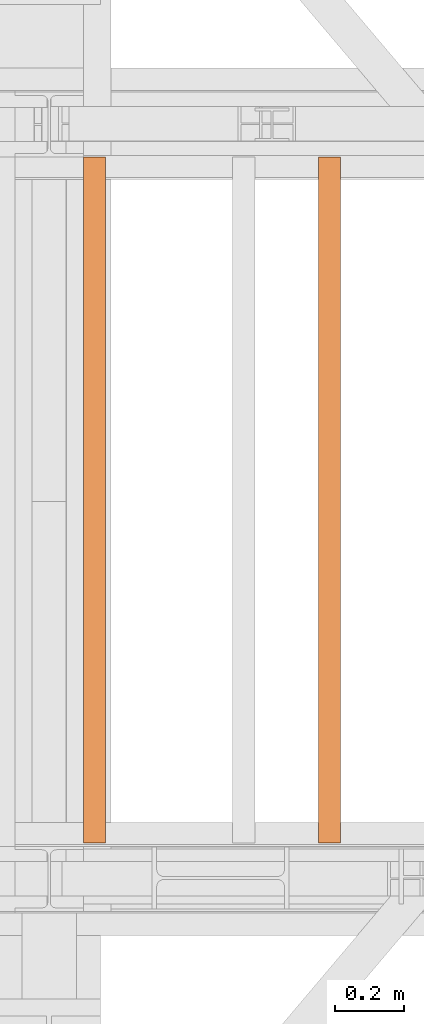
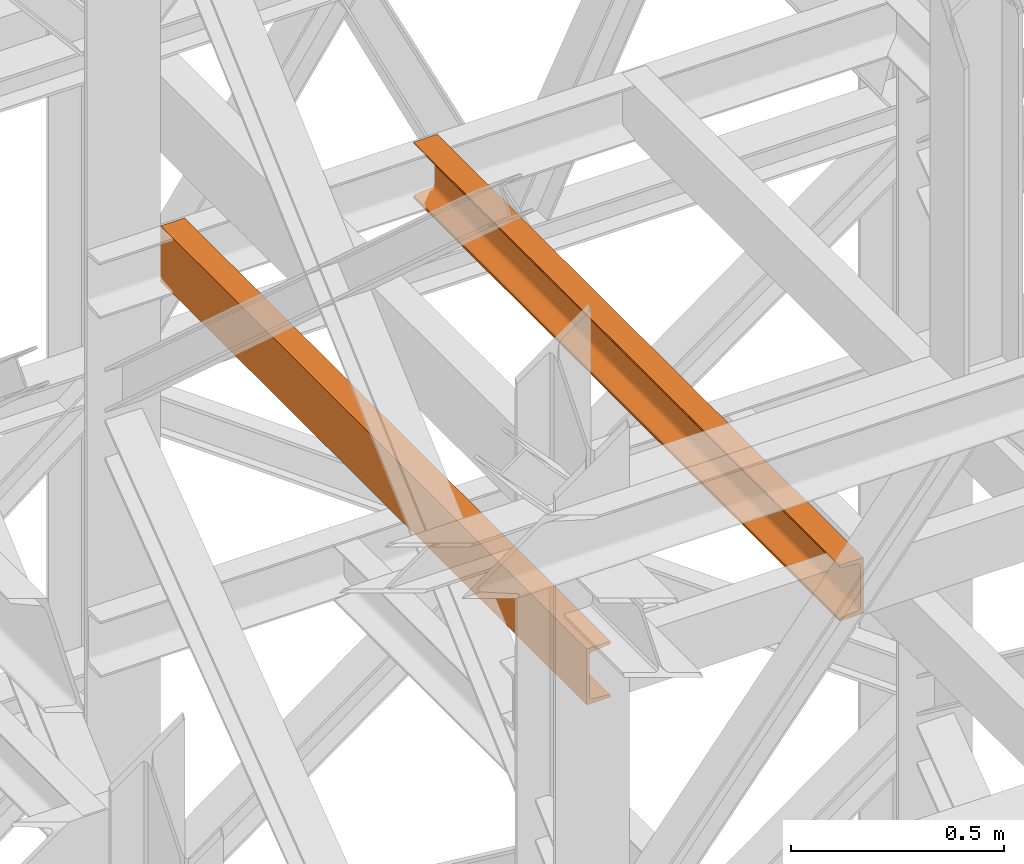
# One storey, part 169 of 208: 2 proxies.
"""IFC2X3 building model written with IfcOpenShell, lengths in millimetres."""

from ifc_helpers import new_model, entity, si_unit, converted_unit, frame, origin, origin_with_axes, place, context, subcontext, project, spatial, faceted_brep, element, save


model = new_model("IFC2X3")

# Units and contexts
model_context = context("Model", 3, precision=1e-05, world=origin())
plan_context = context("Plan", 3, precision=1e-05, world=origin())
body_context = subcontext(model_context, "Body", "Model", "MODEL_VIEW")
ifc_project = project(units=[si_unit("LENGTHUNIT", "METRE", prefix="MILLI"), converted_unit("PLANEANGLEUNIT", "DEGREE", entity("IfcPlaneAngleMeasure", 0.0174532925199433), si_unit("PLANEANGLEUNIT", "RADIAN"), dimensions=[0, 0, 0, 0, 0, 0, 0]), si_unit("AREAUNIT", "SQUARE_METRE"), si_unit("VOLUMEUNIT", "CUBIC_METRE")], contexts=[model_context, plan_context])

# Building, storey
building_placement = place(None, origin())
building = spatial("IfcBuilding", under=ifc_project, at=building_placement, CompositionType="COMPLEX")
storey_placement = place(building_placement, origin_with_axes())
storey = spatial("IfcBuildingStorey", under=building, at=storey_placement, Name="Geschoss", CompositionType="ELEMENT")

# Proxies
proxy_1_placement = place(storey_placement, frame((7378.254968528665, -15857.57439274273, 9109.989999999998), z_axis=(0.0, 0.0, 1.0), x_axis=(1.0, 0.0, 0.0)))
element("IfcBuildingElementProxy", 1, at=proxy_1_placement, inside=storey, context=body_context, shape_type="Brep", body=[
    faceted_brep([(65.01000000000022, 2000.009997019768, 160.0100000000002), (65.01000000000204, 0.01000000000021828, 160.0100000000002), (0.01000000000203727, 0.01000000000021828, 160.0100000000002), (0.01000000000021828, 2000.009997019768, 160.0100000000002), (0.01000000000021828, 2000.009997019768, 160.0100000000002), (0.01000000000203727, 0.01000000000021828, 160.0100000000002), (0.01000000000203727, 0.01000000000021828, 156.8875719297539), (0.01000000000021828, 2000.009997019768, 156.8875719297539), (0.01000000000021828, 2000.009997019768, 156.8875719297539), (0.01000000000203727, 0.01000000000021828, 156.8875719297539), (0.2527365771748009, 0.01000000000021828, 155.2717110918293), (0.2527365771729819, 2000.009997019768, 155.2717110918293), (0.2527365771729819, 2000.009997019768, 155.2717110918293), (0.2527365771748009, 0.01000000000021828, 155.2717110918293), (0.9594677141431021, 0.01000000000021828, 153.7984655565542), (0.959467714144921, 2000.009997019768, 153.7984655565542), (0.959467714144921, 2000.009997019768, 153.7984655565542), (0.9594677141431021, 0.01000000000021828, 153.7984655565542), (2.067848361533834, 0.01000000000021828, 152.5978732961266), (2.067848361532015, 2000.009997019768, 152.5978732961266), (2.067848361532015, 2000.009997019768, 152.5978732961266), (2.067848361533834, 0.01000000000021828, 152.5978732961266), (3.480043588519038, 0.01000000000021828, 151.7759086082897), (3.480043588517219, 2000.009997019768, 151.7759086082897), (3.480043588517219, 2000.009997019768, 151.7759086082897), (3.480043588519038, 0.01000000000021828, 151.7759086082897), (5.071401277447876, 0.01000000000021828, 151.4050878978051), (5.071401277446057, 2000.009997019768, 151.4050878978051), (5.071401277446057, 2000.009997019768, 151.4050878978051), (5.071401277447876, 0.01000000000021828, 151.4050878978051), (47.84732483397238, 0.01000000000021828, 147.9830140132835), (47.84732483397056, 2000.009997019768, 147.9830140132835), (47.84732483397056, 2000.009997019768, 147.9830140132835), (47.84732483397238, 0.01000000000021828, 147.9830140132835), (50.81159179199312, 0.01000000000021828, 147.318026761528), (50.8115917919913, 2000.009997019768, 147.318026761528), (50.8115917919913, 2000.009997019768, 147.318026761528), (50.81159179199312, 0.01000000000021828, 147.318026761528), (53.58138040071208, 0.01000000000021828, 145.7058782528511), (53.5813804007139, 2000.009997019768, 145.7058782528511), (53.5813804007139, 2000.009997019768, 145.7058782528511), (53.58138040071208, 0.01000000000021828, 145.7058782528511), (55.69737981845537, 0.01000000000021828, 143.4138384829421), (55.69737981845356, 2000.009997019768, 143.4138384829421), (55.69737981845356, 2000.009997019768, 143.4138384829421), (55.69737981845537, 0.01000000000021828, 143.4138384829421), (57.04659380721569, 0.01000000000021828, 140.6012788246917), (57.04659380721387, 2000.009997019768, 140.6012788246917), (57.04659380721387, 2000.009997019768, 140.6012788246917), (57.04659380721569, 0.01000000000021828, 140.6012788246917), (57.51000000000204, 0.01000000000021828, 137.5164535886543), (57.51000000000022, 2000.009997019768, 137.5164535886543), (57.51000000000022, 2000.009997019768, 137.5164535886543), (57.51000000000204, 0.01000000000021828, 137.5164535886543), (57.51000000000204, 0.01000000000021828, 22.503546411348), (57.51000000000022, 2000.009997019768, 22.503546411348), (57.51000000000022, 2000.009997019768, 22.503546411348), (57.51000000000204, 0.01000000000021828, 22.503546411348), (57.04659380721569, 0.01000000000021828, 19.41872117530875), (57.04659380721387, 2000.009997019768, 19.41872117530875), (57.04659380721387, 2000.009997019768, 19.41872117530875), (57.04659380721569, 0.01000000000021828, 19.41872117530875), (55.69737981845537, 0.01000000000021828, 16.60616151705835), (55.69737981845356, 2000.009997019768, 16.60616151705835), (55.69737981845356, 2000.009997019768, 16.60616151705835), (55.69737981845537, 0.01000000000021828, 16.60616151705835), (53.58138040071208, 0.01000000000021828, 14.31412174714933), (53.5813804007139, 2000.009997019768, 14.31412174714933), (53.5813804007139, 2000.009997019768, 14.31412174714933), (53.58138040071208, 0.01000000000021828, 14.31412174714933), (50.88537133101636, 0.01000000000021828, 12.74491643400688), (50.88537133101818, 2000.009997019768, 12.74491643400688), (50.88537133101818, 2000.009997019768, 12.74491643400688), (50.88537133101636, 0.01000000000021828, 12.74491643400688), (47.84732483397238, 0.01000000000021828, 12.03698598671872), (47.84732483397056, 2000.009997019768, 12.03698598671872), (47.84732483397056, 2000.009997019768, 12.03698598671872), (47.84732483397238, 0.01000000000021828, 12.03698598671872), (5.071401277447876, 0.01000000000021828, 8.614912102195376), (5.071401277446057, 2000.009997019768, 8.614912102195376), (5.071401277446057, 2000.009997019768, 8.614912102195376), (5.071401277447876, 0.01000000000021828, 8.614912102195376), (3.480043588519038, 0.01000000000021828, 8.244091391710754), (3.480043588517219, 2000.009997019768, 8.244091391710754), (3.480043588517219, 2000.009997019768, 8.244091391710754), (3.480043588519038, 0.01000000000021828, 8.244091391710754), (2.067848361533834, 0.01000000000021828, 7.422126703873801), (2.067848361532015, 2000.009997019768, 7.422126703873801), (2.067848361532015, 2000.009997019768, 7.422126703873801), (2.067848361533834, 0.01000000000021828, 7.422126703873801), (0.9594677141431021, 0.01000000000021828, 6.221534443446217), (0.959467714144921, 2000.009997019768, 6.221534443446217), (0.959467714144921, 2000.009997019768, 6.221534443446217), (0.9594677141431021, 0.01000000000021828, 6.221534443446217), (0.2527365771748009, 0.01000000000021828, 4.748288908172981), (0.2527365771729819, 2000.009997019768, 4.748288908172981), (0.2527365771729819, 2000.009997019768, 4.748288908172981), (0.2527365771748009, 0.01000000000021828, 4.748288908172981), (0.01000000000203727, 0.01000000000021828, 0.01000000000021828), (0.01000000000021828, 2000.009997019768, 0.01000000000021828), (0.01000000000021828, 2000.009997019768, 0.01000000000021828), (0.01000000000203727, 0.01000000000021828, 0.01000000000021828), (65.01000000000204, 0.01000000000021828, 0.01000000000021828), (65.01000000000022, 2000.009997019768, 0.01000000000021828), (65.01000000000022, 2000.009997019768, 0.01000000000021828), (65.01000000000204, 0.01000000000021828, 0.01000000000021828), (65.01000000000204, 0.01000000000021828, 160.0100000000002), (65.01000000000022, 2000.009997019768, 160.0100000000002), (65.01000000000022, 2000.009997019768, 160.0100000000002), (0.01000000000021828, 2000.009997019768, 160.0100000000002), (0.01000000000021828, 2000.009997019768, 156.8875719297539), (0.2527365771729819, 2000.009997019768, 155.2717110918293), (0.959467714144921, 2000.009997019768, 153.7984655565542), (2.067848361532015, 2000.009997019768, 152.5978732961266), (3.480043588517219, 2000.009997019768, 151.7759086082897), (5.071401277446057, 2000.009997019768, 151.4050878978051), (47.84732483397056, 2000.009997019768, 147.9830140132835), (50.8115917919913, 2000.009997019768, 147.318026761528), (53.5813804007139, 2000.009997019768, 145.7058782528511), (55.69737981845356, 2000.009997019768, 143.4138384829421), (57.04659380721387, 2000.009997019768, 140.6012788246917), (57.51000000000022, 2000.009997019768, 137.5164535886543), (57.51000000000022, 2000.009997019768, 22.503546411348), (57.04659380721387, 2000.009997019768, 19.41872117530875), (55.69737981845356, 2000.009997019768, 16.60616151705835), (53.5813804007139, 2000.009997019768, 14.31412174714933), (50.88537133101818, 2000.009997019768, 12.74491643400688), (47.84732483397056, 2000.009997019768, 12.03698598671872), (5.071401277446057, 2000.009997019768, 8.614912102195376), (3.480043588517219, 2000.009997019768, 8.244091391710754), (2.067848361532015, 2000.009997019768, 7.422126703873801), (0.959467714144921, 2000.009997019768, 6.221534443446217), (0.2527365771729819, 2000.009997019768, 4.748288908172981), (0.01000000000021828, 2000.009997019768, 0.01000000000021828), (65.01000000000022, 2000.009997019768, 0.01000000000021828), (65.01000000000204, 0.01000000000021828, 160.0100000000002), (65.01000000000204, 0.01000000000021828, 0.01000000000021828), (0.01000000000203727, 0.01000000000021828, 0.01000000000021828), (0.2527365771748009, 0.01000000000021828, 4.748288908172981), (0.9594677141431021, 0.01000000000021828, 6.221534443446217), (2.067848361533834, 0.01000000000021828, 7.422126703873801), (3.480043588519038, 0.01000000000021828, 8.244091391710754), (5.071401277447876, 0.01000000000021828, 8.614912102195376), (47.84732483397238, 0.01000000000021828, 12.03698598671872), (50.88537133101636, 0.01000000000021828, 12.74491643400688), (53.58138040071208, 0.01000000000021828, 14.31412174714933), (55.69737981845537, 0.01000000000021828, 16.60616151705835), (57.04659380721569, 0.01000000000021828, 19.41872117530875), (57.51000000000204, 0.01000000000021828, 22.503546411348), (57.51000000000204, 0.01000000000021828, 137.5164535886543), (57.04659380721569, 0.01000000000021828, 140.6012788246917), (55.69737981845537, 0.01000000000021828, 143.4138384829421), (53.58138040071208, 0.01000000000021828, 145.7058782528511), (50.81159179199312, 0.01000000000021828, 147.318026761528), (47.84732483397238, 0.01000000000021828, 147.9830140132835), (5.071401277447876, 0.01000000000021828, 151.4050878978051), (3.480043588519038, 0.01000000000021828, 151.7759086082897), (2.067848361533834, 0.01000000000021828, 152.5978732961266), (0.9594677141431021, 0.01000000000021828, 153.7984655565542), (0.2527365771748009, 0.01000000000021828, 155.2717110918293), (0.01000000000203727, 0.01000000000021828, 156.8875719297539), (0.01000000000203727, 0.01000000000021828, 160.0100000000002)], [[[0, 1, 2, 3]], [[4, 5, 6, 7]], [[8, 9, 10, 11]], [[12, 13, 14, 15]], [[16, 17, 18, 19]], [[20, 21, 22, 23]], [[24, 25, 26, 27]], [[28, 29, 30, 31]], [[32, 33, 34, 35]], [[36, 37, 38, 39]], [[40, 41, 42, 43]], [[44, 45, 46, 47]], [[48, 49, 50, 51]], [[52, 53, 54, 55]], [[56, 57, 58, 59]], [[60, 61, 62, 63]], [[64, 65, 66, 67]], [[68, 69, 70, 71]], [[72, 73, 74, 75]], [[76, 77, 78, 79]], [[80, 81, 82, 83]], [[84, 85, 86, 87]], [[88, 89, 90, 91]], [[92, 93, 94, 95]], [[96, 97, 98, 99]], [[100, 101, 102, 103]], [[104, 105, 106, 107]], [[108, 109, 110, 111, 112, 113, 114, 115, 116, 117, 118, 119, 120, 121, 122, 123, 124, 125, 126, 127, 128, 129, 130, 131, 132, 133, 134]], [[135, 136, 137, 138, 139, 140, 141, 142, 143, 144, 145, 146, 147, 148, 149, 150, 151, 152, 153, 154, 155, 156, 157, 158, 159, 160, 161]]], orient=[[False], [False], [False], [False], [False], [False], [False], [False], [False], [False], [False], [False], [False], [False], [False], [False], [False], [False], [False], [False], [False], [False], [False], [False], [False], [False], [False], [False], [False]]),
])
proxy_2_placement = place(storey_placement, frame((6693.254970018781, -15857.57439274273, 9109.989999999998), z_axis=(0.0, 0.0, 1.0), x_axis=(1.0, 0.0, 0.0)))
element("IfcBuildingElementProxy", 2, at=proxy_2_placement, inside=storey, context=body_context, shape_type="Brep", body=[
    faceted_brep([(0.01000000000203727, 2000.009997019768, 160.0100000000002), (65.01000000000204, 2000.009997019768, 160.0100000000002), (65.01000000000022, 0.01000000000021828, 160.0100000000002), (0.01000000000021828, 0.01000000000021828, 160.0100000000002), (65.01000000000204, 2000.009997019768, 160.0100000000002), (65.01000000000204, 2000.009997019768, 156.8875719297539), (65.01000000000022, 0.01000000000021828, 156.8875719297539), (65.01000000000022, 0.01000000000021828, 160.0100000000002), (65.01000000000204, 2000.009997019768, 156.8875719297539), (64.76726342282927, 2000.009997019768, 155.2717110918293), (64.76726342282745, 0.01000000000021828, 155.2717110918293), (65.01000000000022, 0.01000000000021828, 156.8875719297539), (64.76726342282927, 2000.009997019768, 155.2717110918293), (64.06053228585733, 2000.009997019768, 153.7984655565542), (64.06053228585915, 0.01000000000021828, 153.7984655565542), (64.76726342282745, 0.01000000000021828, 155.2717110918293), (64.06053228585733, 2000.009997019768, 153.7984655565542), (62.95215163847024, 2000.009997019768, 152.5978732961266), (62.95215163846842, 0.01000000000021828, 152.5978732961266), (64.06053228585915, 0.01000000000021828, 153.7984655565542), (62.95215163847024, 2000.009997019768, 152.5978732961266), (61.53995641148504, 2000.009997019768, 151.7759086082897), (61.53995641148322, 0.01000000000021828, 151.7759086082897), (62.95215163846842, 0.01000000000021828, 152.5978732961266), (61.53995641148504, 2000.009997019768, 151.7759086082897), (59.9485987225562, 2000.009997019768, 151.4050878978051), (59.94859872255438, 0.01000000000021828, 151.4050878978051), (61.53995641148322, 0.01000000000021828, 151.7759086082897), (59.9485987225562, 2000.009997019768, 151.4050878978051), (17.1726751660317, 2000.009997019768, 147.9830140132835), (17.17267516602988, 0.01000000000021828, 147.9830140132835), (59.94859872255438, 0.01000000000021828, 151.4050878978051), (17.1726751660317, 2000.009997019768, 147.9830140132835), (14.20840820801095, 2000.009997019768, 147.318026761528), (14.20840820800913, 0.01000000000021828, 147.318026761528), (17.17267516602988, 0.01000000000021828, 147.9830140132835), (14.20840820801095, 2000.009997019768, 147.318026761528), (11.43861959928836, 2000.009997019768, 145.7058782528511), (11.43861959929018, 0.01000000000021828, 145.7058782528511), (14.20840820800913, 0.01000000000021828, 147.318026761528), (11.43861959928836, 2000.009997019768, 145.7058782528511), (9.3226201815487, 2000.009997019768, 143.4138384829421), (9.322620181546881, 0.01000000000021828, 143.4138384829421), (11.43861959929018, 0.01000000000021828, 145.7058782528511), (9.3226201815487, 2000.009997019768, 143.4138384829421), (7.973406192788389, 2000.009997019768, 140.6012788246917), (7.97340619278657, 0.01000000000021828, 140.6012788246917), (9.322620181546881, 0.01000000000021828, 143.4138384829421), (7.973406192788389, 2000.009997019768, 140.6012788246917), (7.510000000002037, 2000.009997019768, 137.5164535886543), (7.510000000000218, 0.01000000000021828, 137.5164535886543), (7.97340619278657, 0.01000000000021828, 140.6012788246917), (7.510000000002037, 2000.009997019768, 137.5164535886543), (7.510000000002037, 2000.009997019768, 22.503546411348), (7.510000000000218, 0.01000000000021828, 22.503546411348), (7.510000000000218, 0.01000000000021828, 137.5164535886543), (7.510000000002037, 2000.009997019768, 22.503546411348), (7.973406192788389, 2000.009997019768, 19.41872117530875), (7.97340619278657, 0.01000000000021828, 19.41872117530875), (7.510000000000218, 0.01000000000021828, 22.503546411348), (7.973406192788389, 2000.009997019768, 19.41872117530875), (9.3226201815487, 2000.009997019768, 16.60616151705835), (9.322620181546881, 0.01000000000021828, 16.60616151705835), (7.97340619278657, 0.01000000000021828, 19.41872117530875), (9.3226201815487, 2000.009997019768, 16.60616151705835), (11.43861959928836, 2000.009997019768, 14.31412174714933), (11.43861959929018, 0.01000000000021828, 14.31412174714933), (9.322620181546881, 0.01000000000021828, 16.60616151705835), (11.43861959928836, 2000.009997019768, 14.31412174714933), (14.13462866898408, 2000.009997019768, 12.74491643400688), (14.1346286689859, 0.01000000000021828, 12.74491643400688), (11.43861959929018, 0.01000000000021828, 14.31412174714933), (14.13462866898408, 2000.009997019768, 12.74491643400688), (17.1726751660317, 2000.009997019768, 12.03698598671872), (17.17267516602988, 0.01000000000021828, 12.03698598671872), (14.1346286689859, 0.01000000000021828, 12.74491643400688), (17.1726751660317, 2000.009997019768, 12.03698598671872), (59.9485987225562, 2000.009997019768, 8.614912102195376), (59.94859872255438, 0.01000000000021828, 8.614912102195376), (17.17267516602988, 0.01000000000021828, 12.03698598671872), (59.9485987225562, 2000.009997019768, 8.614912102195376), (61.53995641148504, 2000.009997019768, 8.244091391710754), (61.53995641148322, 0.01000000000021828, 8.244091391710754), (59.94859872255438, 0.01000000000021828, 8.614912102195376), (61.53995641148504, 2000.009997019768, 8.244091391710754), (62.95215163847024, 2000.009997019768, 7.422126703873801), (62.95215163846842, 0.01000000000021828, 7.422126703873801), (61.53995641148322, 0.01000000000021828, 8.244091391710754), (62.95215163847024, 2000.009997019768, 7.422126703873801), (64.06053228585733, 2000.009997019768, 6.221534443446217), (64.06053228585915, 0.01000000000021828, 6.221534443446217), (62.95215163846842, 0.01000000000021828, 7.422126703873801), (64.06053228585733, 2000.009997019768, 6.221534443446217), (64.76726342282927, 2000.009997019768, 4.748288908172981), (64.76726342282745, 0.01000000000021828, 4.748288908172981), (64.06053228585915, 0.01000000000021828, 6.221534443446217), (64.76726342282927, 2000.009997019768, 4.748288908172981), (65.01000000000204, 2000.009997019768, 0.01000000000021828), (65.01000000000022, 0.01000000000021828, 0.01000000000021828), (64.76726342282745, 0.01000000000021828, 4.748288908172981), (65.01000000000204, 2000.009997019768, 0.01000000000021828), (0.01000000000203727, 2000.009997019768, 0.01000000000021828), (0.01000000000021828, 0.01000000000021828, 0.01000000000021828), (65.01000000000022, 0.01000000000021828, 0.01000000000021828), (0.01000000000203727, 2000.009997019768, 0.01000000000021828), (0.01000000000203727, 2000.009997019768, 160.0100000000002), (0.01000000000021828, 0.01000000000021828, 160.0100000000002), (0.01000000000021828, 0.01000000000021828, 0.01000000000021828), (0.01000000000203727, 2000.009997019768, 160.0100000000002), (0.01000000000203727, 2000.009997019768, 0.01000000000021828), (65.01000000000204, 2000.009997019768, 0.01000000000021828), (64.76726342282927, 2000.009997019768, 4.748288908172981), (64.06053228585733, 2000.009997019768, 6.221534443446217), (62.95215163847024, 2000.009997019768, 7.422126703873801), (61.53995641148504, 2000.009997019768, 8.244091391710754), (59.9485987225562, 2000.009997019768, 8.614912102195376), (17.1726751660317, 2000.009997019768, 12.03698598671872), (14.13462866898408, 2000.009997019768, 12.74491643400688), (11.43861959928836, 2000.009997019768, 14.31412174714933), (9.3226201815487, 2000.009997019768, 16.60616151705835), (7.973406192788389, 2000.009997019768, 19.41872117530875), (7.510000000002037, 2000.009997019768, 22.503546411348), (7.510000000002037, 2000.009997019768, 137.5164535886543), (7.973406192788389, 2000.009997019768, 140.6012788246917), (9.3226201815487, 2000.009997019768, 143.4138384829421), (11.43861959928836, 2000.009997019768, 145.7058782528511), (14.20840820801095, 2000.009997019768, 147.318026761528), (17.1726751660317, 2000.009997019768, 147.9830140132835), (59.9485987225562, 2000.009997019768, 151.4050878978051), (61.53995641148504, 2000.009997019768, 151.7759086082897), (62.95215163847024, 2000.009997019768, 152.5978732961266), (64.06053228585733, 2000.009997019768, 153.7984655565542), (64.76726342282927, 2000.009997019768, 155.2717110918293), (65.01000000000204, 2000.009997019768, 156.8875719297539), (65.01000000000204, 2000.009997019768, 160.0100000000002), (0.01000000000021828, 0.01000000000021828, 160.0100000000002), (65.01000000000022, 0.01000000000021828, 160.0100000000002), (65.01000000000022, 0.01000000000021828, 156.8875719297539), (64.76726342282745, 0.01000000000021828, 155.2717110918293), (64.06053228585915, 0.01000000000021828, 153.7984655565542), (62.95215163846842, 0.01000000000021828, 152.5978732961266), (61.53995641148322, 0.01000000000021828, 151.7759086082897), (59.94859872255438, 0.01000000000021828, 151.4050878978051), (17.17267516602988, 0.01000000000021828, 147.9830140132835), (14.20840820800913, 0.01000000000021828, 147.318026761528), (11.43861959929018, 0.01000000000021828, 145.7058782528511), (9.322620181546881, 0.01000000000021828, 143.4138384829421), (7.97340619278657, 0.01000000000021828, 140.6012788246917), (7.510000000000218, 0.01000000000021828, 137.5164535886543), (7.510000000000218, 0.01000000000021828, 22.503546411348), (7.97340619278657, 0.01000000000021828, 19.41872117530875), (9.322620181546881, 0.01000000000021828, 16.60616151705835), (11.43861959929018, 0.01000000000021828, 14.31412174714933), (14.1346286689859, 0.01000000000021828, 12.74491643400688), (17.17267516602988, 0.01000000000021828, 12.03698598671872), (59.94859872255438, 0.01000000000021828, 8.614912102195376), (61.53995641148322, 0.01000000000021828, 8.244091391710754), (62.95215163846842, 0.01000000000021828, 7.422126703873801), (64.06053228585915, 0.01000000000021828, 6.221534443446217), (64.76726342282745, 0.01000000000021828, 4.748288908172981), (65.01000000000022, 0.01000000000021828, 0.01000000000021828), (0.01000000000021828, 0.01000000000021828, 0.01000000000021828)], [[[0, 1, 2, 3]], [[4, 5, 6, 7]], [[8, 9, 10, 11]], [[12, 13, 14, 15]], [[16, 17, 18, 19]], [[20, 21, 22, 23]], [[24, 25, 26, 27]], [[28, 29, 30, 31]], [[32, 33, 34, 35]], [[36, 37, 38, 39]], [[40, 41, 42, 43]], [[44, 45, 46, 47]], [[48, 49, 50, 51]], [[52, 53, 54, 55]], [[56, 57, 58, 59]], [[60, 61, 62, 63]], [[64, 65, 66, 67]], [[68, 69, 70, 71]], [[72, 73, 74, 75]], [[76, 77, 78, 79]], [[80, 81, 82, 83]], [[84, 85, 86, 87]], [[88, 89, 90, 91]], [[92, 93, 94, 95]], [[96, 97, 98, 99]], [[100, 101, 102, 103]], [[104, 105, 106, 107]], [[108, 109, 110, 111, 112, 113, 114, 115, 116, 117, 118, 119, 120, 121, 122, 123, 124, 125, 126, 127, 128, 129, 130, 131, 132, 133, 134]], [[135, 136, 137, 138, 139, 140, 141, 142, 143, 144, 145, 146, 147, 148, 149, 150, 151, 152, 153, 154, 155, 156, 157, 158, 159, 160, 161]]], orient=[[False], [False], [False], [False], [False], [False], [False], [False], [False], [False], [False], [False], [False], [False], [False], [False], [False], [False], [False], [False], [False], [False], [False], [False], [False], [False], [False], [False], [False]]),
])

save(model, "model.ifc")
